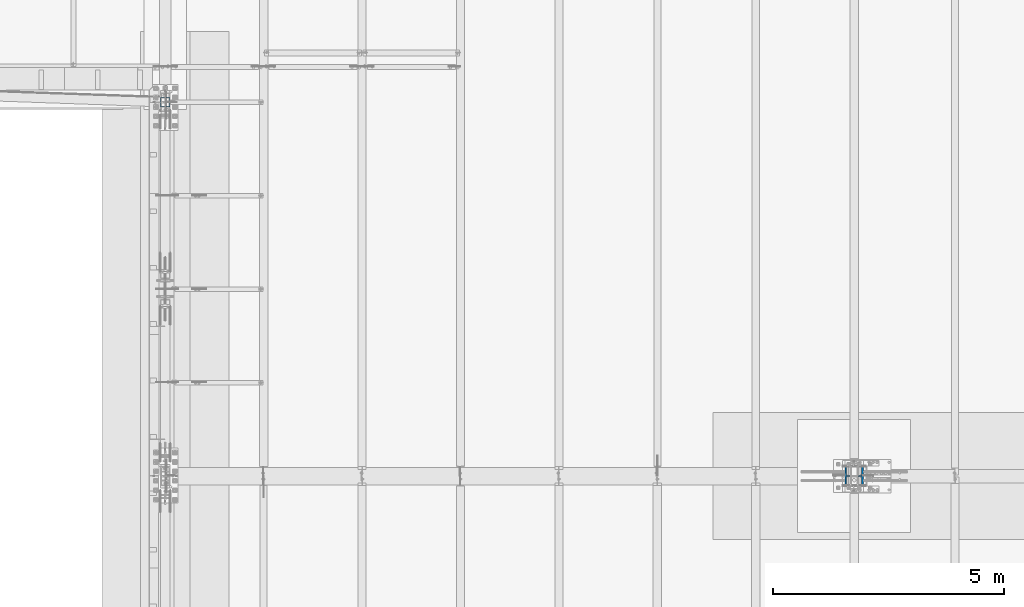
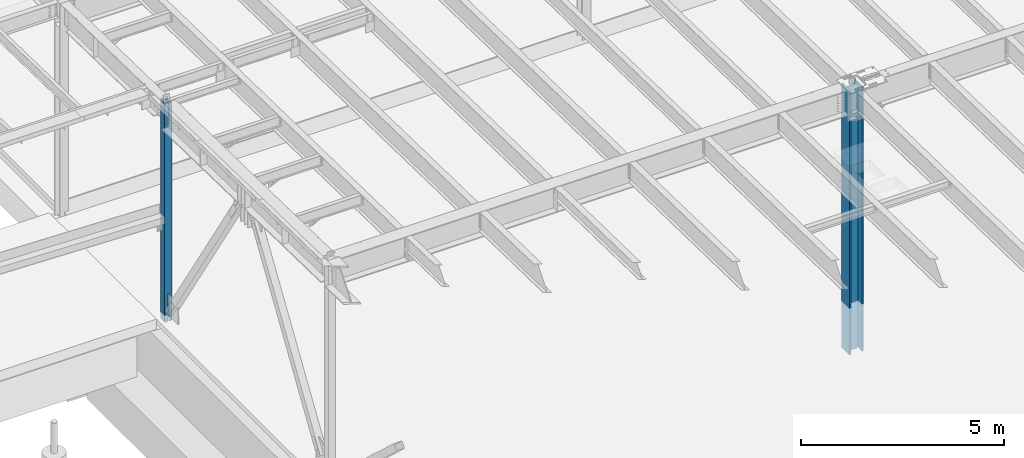
# One storey, part 887 of 1763: 2 columns, 2 elements without a shape of their own.
"""IFC2X3 building model written with IfcOpenShell, lengths in millimetres."""

import ifcopenshell
import ifcopenshell.guid

model = None  # the IFC model being written
_history = None  # IfcOwnerHistory: only IFC2X3 demands one
_inside = {}  # id of a spatial element -> (the spatial element, [elements in it])
_under = {}  # id of a project, library or spatial element -> (it, [spatial elements below it])
_declared = {}  # id of a project -> (the project, [libraries it declares])
_typed = {}  # id of a type object -> (the type object, [elements of that type])
_made_of = {}  # id of a material, layer set ... -> (it, [elements and type objects made of it])


def new_model(schema):
    """Start an empty IFC model of exactly this schema.

    Asked for "IFC4X3", IfcOpenShell would pick the latest addendum, in which some entities
    have other attributes; the version numbers below select the first issue.
    IFC2X3 requires an IfcOwnerHistory on every rooted entity: one is made here for all.
    """
    global model, _history
    if schema == "IFC4X3":
        model = ifcopenshell.file(schema_version=(4, 3, 0, 0))
    else:
        model = ifcopenshell.file(schema=schema)
    _inside.clear()
    _under.clear()
    _declared.clear()
    _typed.clear()
    _made_of.clear()
    _history = None
    if model.schema == "IFC2X3":
        org = make("IfcOrganization", Name="unknown")
        user = make(
            "IfcPersonAndOrganization",
            ThePerson=make("IfcPerson", FamilyName="unknown"),
            TheOrganization=org,
        )
        app = make(
            "IfcApplication",
            ApplicationDeveloper=org,
            Version="unknown",
            ApplicationFullName="unknown",
            ApplicationIdentifier="unknown",
        )
        _history = make(
            "IfcOwnerHistory",
            OwningUser=user,
            OwningApplication=app,
            ChangeAction="ADDED",
            CreationDate=0,
        )
    return model


def make(cls, **values):
    """One entity of the class cls with the attributes given. An attribute that is None is left unset."""
    return model.create_entity(
        cls, **{name: value for name, value in values.items() if value is not None}
    )


def rooted(cls, **values):
    """An entity with a GlobalId (a new one), such as an element, a storey or a relation."""
    return make(cls, GlobalId=ifcopenshell.guid.new(), OwnerHistory=_history, **values)


def si_unit(unit_type, name, prefix=None):
    """IfcSIUnit, for example si_unit("LENGTHUNIT", "METRE", prefix="MILLI")."""
    return make("IfcSIUnit", UnitType=unit_type, Prefix=prefix, Name=name)


def assignment(units):
    """IfcUnitAssignment: the units of a project."""
    return None if units is None else make("IfcUnitAssignment", Units=units)


def point(xyz):
    """IfcCartesianPoint."""
    return None if xyz is None else make("IfcCartesianPoint", Coordinates=xyz)


def direction(xyz):
    """IfcDirection."""
    return None if xyz is None else make("IfcDirection", DirectionRatios=xyz)


def frame(location, z_axis=None, x_axis=None):
    """IfcAxis2Placement3D, a coordinate frame: its origin and axes. An axis left out is left unset."""
    return make(
        "IfcAxis2Placement3D",
        Location=point(location),
        Axis=direction(z_axis),
        RefDirection=direction(x_axis),
    )


def origin_with_axes():
    """The frame at (0, 0, 0) with the z axis (0, 0, 1) and the x axis (1, 0, 0) written out."""
    return frame((0.0, 0.0, 0.0), z_axis=(0.0, 0.0, 1.0), x_axis=(1.0, 0.0, 0.0))


def place(relative_to, where):
    """IfcLocalPlacement: puts the frame where relative to a parent placement (None: the world)."""
    return make(
        "IfcLocalPlacement", PlacementRelTo=relative_to, RelativePlacement=where
    )


def context(
    kind, dimensions, precision=None, world=None, true_north=None, identifier=None
):
    """IfcGeometricRepresentationContext, for example the 3D "Model" context."""
    return make(
        "IfcGeometricRepresentationContext",
        ContextIdentifier=identifier,
        ContextType=kind,
        CoordinateSpaceDimension=dimensions,
        Precision=precision,
        WorldCoordinateSystem=world,
        TrueNorth=true_north,
    )


def subcontext(parent, identifier, kind, view, scale=None):
    """IfcGeometricRepresentationSubContext, for example "Body" below "Model"."""
    return make(
        "IfcGeometricRepresentationSubContext",
        ContextIdentifier=identifier,
        ContextType=kind,
        ParentContext=parent,
        TargetScale=scale,
        TargetView=view,
    )


def project(units=None, contexts=None):
    """IfcProject with its units and contexts."""
    return rooted(
        "IfcProject",
        Name="project",
        RepresentationContexts=contexts,
        UnitsInContext=assignment(units),
    )


def spatial(cls, under=None, at=None, **own):
    """A site, building, storey or space (cls), placed at a placement, below another one or the project."""
    s = rooted(cls, ObjectPlacement=at, **own)
    if under is not None:
        _under.setdefault(under.id(), (under, []))[1].append(s)
    return s


def faces_of(points, faces, orient=None, outer=None):
    """IfcFace entities. A face is a list of loops; a loop is a list of indices into points, from 0.

    orient and outer hold one flag for each loop. By default every Orientation is true, the
    first loop of a face is its IfcFaceOuterBound and the others are IfcFaceBound.
    """
    made = []
    for i, loops in enumerate(faces):
        bounds = []
        for j, loop in enumerate(loops):
            is_outer = j == 0 if outer is None else outer[i][j]
            bounds.append(
                make(
                    "IfcFaceOuterBound" if is_outer else "IfcFaceBound",
                    Bound=make("IfcPolyLoop", Polygon=[points[k] for k in loop]),
                    Orientation=True if orient is None else orient[i][j],
                )
            )
        made.append(make("IfcFace", Bounds=bounds))
    return made


def faceted_brep(points, faces, orient=None, outer=None, voids=None):
    """IfcFacetedBrep: a solid bounded by flat faces; with voids (closed shells), ...WithVoids."""
    shared = [point(p) for p in points]
    hull = make("IfcClosedShell", CfsFaces=faces_of(shared, faces, orient, outer))
    if voids is None:
        return make("IfcFacetedBrep", Outer=hull)
    return make(
        "IfcFacetedBrepWithVoids",
        Outer=hull,
        Voids=[
            make(cls, CfsFaces=faces_of(shared, fs, o, b)) for cls, fs, o, b in voids
        ],
    )


def shape(context_of_items, identifier, shape_type, items):
    """IfcShapeRepresentation: the items that make up one representation, for example the "Body"."""
    return make(
        "IfcShapeRepresentation",
        ContextOfItems=context_of_items,
        RepresentationIdentifier=identifier,
        RepresentationType=shape_type,
        Items=items,
    )


def material(Name=None, Category=None):
    """IfcMaterial."""
    return make("IfcMaterial", Name=Name, Category=Category)


def made_of(thing, what):
    """Note that an element or type object is made of a material, layer set ...; save() writes the relation."""
    if what is not None:
        _made_of.setdefault(what.id(), (what, []))[1].append(thing)
    return thing


def type_object(cls, material=None, **own):
    """A type object (cls), such as IfcWallType, which elements share."""
    return made_of(rooted(cls, **own), material)


def element(
    cls,
    number,
    at=None,
    inside=None,
    cuts=None,
    type_object=None,
    material=None,
    context=None,
    identifier="Body",
    shape_type=None,
    held_by="IfcProductDefinitionShape",
    body=None,
    shapes=None,
    **own,
):
    """One element of the class cls, such as IfcWall. Its Tag is "e" and its number.

    at: its placement. inside: the storey or other place that contains it. cuts: it is an
    opening in that element (IfcRelVoidsElement). A single representation is given by context,
    identifier, shape_type and body (its items); several are given by shapes. held_by: the class
    of the entity that holds the representations. save() writes the other relations.
    """
    e = rooted(cls, Tag="e%d" % number, ObjectPlacement=at, **own)
    if body is not None:
        shapes = [shape(context, identifier, shape_type, body)]
    if shapes is not None:
        e.Representation = make(held_by, Representations=shapes)
    if inside is not None:
        _inside.setdefault(inside.id(), (inside, []))[1].append(e)
    if cuts is not None:
        rooted(
            "IfcRelVoidsElement", RelatingBuildingElement=cuts, RelatedOpeningElement=e
        )
    if type_object is not None:
        _typed.setdefault(type_object.id(), (type_object, []))[1].append(e)
    return made_of(e, material)


def aggregate(whole, parts):
    """IfcRelAggregates: a whole, such as a stair, and the parts it consists of."""
    return rooted("IfcRelAggregates", RelatingObject=whole, RelatedObjects=parts)


def save(model, path):
    """Write the relations noted so far, then the file.

    IfcRelAggregates (storeys below a building ...), IfcRelContainedInSpatialStructure (elements
    in a storey), IfcRelDefinesByType, IfcRelAssociatesMaterial and IfcRelDeclares: one each for
    every whole, place, type object, material and project.
    """
    for whole, parts in _under.values():
        aggregate(whole, parts)
    for where, things in _inside.values():
        rooted(
            "IfcRelContainedInSpatialStructure",
            RelatedElements=things,
            RelatingStructure=where,
        )
    for kind, things in _typed.values():
        rooted("IfcRelDefinesByType", RelatedObjects=things, RelatingType=kind)
    for what, things in _made_of.values():
        rooted("IfcRelAssociatesMaterial", RelatedObjects=things, RelatingMaterial=what)
    for by, libraries in _declared.values():
        rooted("IfcRelDeclares", RelatingContext=by, RelatedDefinitions=libraries)
    model.write(path)


model = new_model("IFC2X3")

# Units and contexts
model_context = context("Model", 3, precision=1e-05, world=origin_with_axes())
body_context = subcontext(model_context, "Body", "Model", "MODEL_VIEW")
ifc_project = project(units=[si_unit("LENGTHUNIT", "METRE", prefix="MILLI"), si_unit("AREAUNIT", "SQUARE_METRE"), si_unit("VOLUMEUNIT", "CUBIC_METRE"), si_unit("MASSUNIT", "GRAM", prefix="KILO"), si_unit("TIMEUNIT", "SECOND"), si_unit("PLANEANGLEUNIT", "RADIAN"), si_unit("SOLIDANGLEUNIT", "STERADIAN"), si_unit("THERMODYNAMICTEMPERATUREUNIT", "DEGREE_CELSIUS"), si_unit("LUMINOUSINTENSITYUNIT", "LUMEN")], contexts=[model_context])

# Site, building, storey
site_placement = place(None, origin_with_axes())
site = spatial("IfcSite", under=ifc_project, at=site_placement, CompositionType="ELEMENT")
building_placement = place(site_placement, origin_with_axes())
building = spatial("IfcBuilding", under=site, at=building_placement, Name="Undefined", CompositionType="ELEMENT")
storey_placement = place(building_placement, origin_with_axes())
storey = spatial("IfcBuildingStorey", under=building, at=storey_placement, Name="Undefined", CompositionType="ELEMENT", Elevation=0.0)

# Assembly, column
assembly_1_placement = place(storey_placement, origin_with_axes())
assembly_1 = element("IfcElementAssembly", 1, at=assembly_1_placement, inside=storey, Name="COLUMN", AssemblyPlace="NOTDEFINED", PredefinedType="RIGID_FRAME")
ifc_material_1 = material()
column_type_1 = type_object("IfcColumnType", Name="HSS8X8X1/2", PredefinedType="NOTDEFINED")
column_1_placement = place(assembly_1_placement, frame((-87375.4372736983, 8534.40000000001, 5029.2), z_axis=(0.0, 1.0, 0.0), x_axis=(0.0, 0.0, 1.0)))
column_1 = element("IfcColumn", 2, at=column_1_placement, type_object=column_type_1, material=ifc_material_1, Name="COLUMN", ObjectType="HSS8X8X1/2", context=body_context, shape_type="Brep", body=[
    faceted_brep([(6684.93484998607, -88.8999999999942, -88.8999999999996), (6672.23484998607, -101.600000000006, -101.6), (6672.23484998607, 4.76249961853318, -101.6), (6684.93484998607, 4.76249961853318, -88.8999999999996), (6684.93484998607, -88.8999999999942, 88.8999999999996), (6672.23484998607, -101.600000000006, 101.6), (6684.93484998607, 88.8999999999942, 88.8999999999996), (6684.93484998607, 88.8999999999942, 10.3187499999967), (6672.23484998607, 101.600000000006, 10.3187499999967), (6672.23484998607, 101.600000000006, 101.6), (6684.93484998607, 26.9875000000029, -88.8999999999996), (6672.23484998607, 26.9875000000029, -101.6), (6672.23484998607, 101.600000000006, -101.6), (6684.93484998607, 88.8999999999942, -88.8999999999996), (6684.93484998607, 88.8999999999942, 0.793750381466452), (6672.23484998607, 101.600000000006, 0.793750381466452), (931.497778620195, -13.3207708403497, -88.8999999999996), (931.497778620195, -13.3207708403497, -101.6), (926.63769910215, -14.2875007629336, -101.6), (926.63769910215, -14.2875007629336, -88.8999999999996), (935.617955088349, -10.5677569398686, -88.8999999999996), (935.617955088349, -10.5677569398686, -101.6), (938.370968988827, -6.44758047170762, -88.8999999999996), (938.370968988827, -6.44758047170762, -101.6), (939.337698911415, -1.5875009536685, -88.8999999999996), (939.337698911415, -1.5875009536685, -101.6), (939.337698911415, 1.58750019074068, -88.8999999999996), (939.337698911415, 1.58750019074068, -101.6), (938.370968988827, 6.44757970877981, -88.8999999999996), (938.370968988827, 6.44757970877981, -101.6), (935.617955088349, 10.5677561769407, -88.8999999999996), (935.617955088349, 10.5677561769407, -101.6), (931.497778620195, 13.3207700774219, -88.8999999999996), (931.497778620195, 13.3207700774219, -101.6), (926.63769910215, 14.2875000000058, -88.8999999999996), (926.63769910215, 14.2875000000058, -101.6), (101.599999999998, 14.2875007629627, -88.9), (101.599999999998, 14.2875007629627, -101.6), (6511.84203632012, 88.8999999999942, 10.3187499999967), (6511.84203632012, 101.600000000006, 10.3187499999967), (6510.37034294335, 88.8999999999942, 10.0856566681869), (6510.37034294335, 101.600000000006, 10.0856566681869), (6509.04270916819, 88.8999999999942, 9.40919347213458), (6509.04270916819, 101.600000000006, 9.40919347213458), (6507.98909303872, 88.8999999999942, 8.35557734266331), (6507.98909303872, 101.600000000006, 8.35557734266331), (6507.31262984266, 88.8999999999942, 7.02794356750201), (6507.31262984266, 101.600000000006, 7.02794356750201), (6507.07953651085, 88.8999999999942, 5.55625019073159), (6507.07953651085, 101.600000000006, 5.55625019073159), (6507.31262984266, 88.8999999999942, 4.08455681396117), (6507.31262984266, 101.600000000006, 4.08455681396117), (6507.98909303872, 88.8999999999942, 2.75692303879987), (6507.98909303872, 101.600000000006, 2.75692303879987), (6509.04270916819, 88.8999999999942, 1.7033069093286), (6509.04270916819, 101.600000000006, 1.7033069093286), (6510.37034294335, 88.8999999999942, 1.02684371327632), (6510.37034294335, 101.600000000006, 1.02684371327632), (6511.84203632012, 88.8999999999942, 0.793750381466452), (6511.84203632012, 101.600000000006, 0.793750381466452), (6028.5118970698, 4.76249961853318, 88.8999999999996), (6028.5118970698, 4.76249961853318, 101.6), (6672.23484998607, 4.76249961853318, 101.6), (6684.93484998607, 4.76249961853318, 88.8999999999996), (6024.25932735465, 5.60838832802256, 88.8999999999996), (6024.25932735465, 5.60838832802256, 101.6), (6020.65417282899, 8.01727556846163, 88.8999999999996), (6020.65417282899, 8.01727556846163, 101.6), (6018.24528558855, 11.6224300941249, 88.8999999999996), (6018.24528558855, 11.6224300941249, 101.6), (6017.39939687906, 15.874999809268, 88.8999999999996), (6017.39939687906, 15.874999809268, 101.6), (6018.24528558855, 20.1275695244112, 88.8999999999996), (6018.24528558855, 20.1275695244112, 101.6), (6020.65417282899, 23.7327240500745, 88.8999999999996), (6020.65417282899, 23.7327240500745, 101.6), (6024.25932735465, 26.1416112905135, 88.8999999999996), (6024.25932735465, 26.1416112905135, 101.6), (6028.5118970698, 26.9875000000029, 88.8999999999996), (6028.5118970698, 26.9875000000029, 101.6), (6684.93484998607, 26.9875000000029, 88.8999999999996), (6672.23484998607, 26.9875000000029, 101.6), (101.599999999999, -101.599999999999, 101.6), (101.599999999999, -101.599999999999, -101.6), (101.599999999999, 101.599999999999, 101.6), (101.600000000009, 14.2875007629336, 101.6), (926.63769910215, 14.2875000000058, 101.6), (931.497778620195, 13.3207700774219, 101.6), (935.617955088349, 10.5677561769407, 101.6), (938.370968988827, 6.44757970877981, 101.6), (939.337698911415, 1.58750019074068, 101.6), (939.337698911415, -1.5875009536685, 101.6), (938.370968988827, -6.44758047170762, 101.6), (935.617955088349, -10.5677569398686, 101.6), (931.497778620195, -13.3207708403497, 101.6), (926.63769910215, -14.2875007629336, 101.6), (101.600000000009, -14.2875000000058, 101.6), (101.599999999999, 101.599999999999, -101.6), (6028.51188020661, 26.9875000000029, -88.8999999999996), (6028.51188020661, 26.9875000000029, -101.6), (6024.25931049146, 26.1416112905135, -88.8999999999996), (6024.25931049146, 26.1416112905135, -101.6), (6020.6541559658, 23.7327240500745, -88.8999999999996), (6020.6541559658, 23.7327240500745, -101.6), (6018.24526872536, 20.1275695244112, -88.8999999999996), (6018.24526872536, 20.1275695244112, -101.6), (6017.39938001587, 15.874999809268, -88.8999999999996), (6017.39938001587, 15.874999809268, -101.6), (6018.24526872536, 11.6224300941249, -88.8999999999996), (6018.24526872536, 11.6224300941249, -101.6), (6020.6541559658, 8.01727556846163, -88.8999999999996), (6020.6541559658, 8.01727556846163, -101.6), (6024.25931049146, 5.60838832802256, -88.8999999999996), (6024.25931049146, 5.60838832802256, -101.6), (6028.51188020661, 4.76249961853318, -88.8999999999996), (6028.51188020661, 4.76249961853318, -101.6), (101.599999999998, -14.2874999999622, -101.6), (101.599999999998, -14.2874999999622, -88.9), (101.599999999999, 88.9000000000015, -88.8999999999996), (101.599999999999, -88.9000000000015, -88.8999999999996), (101.599999999999, 88.9000000000015, 88.8999999999996), (101.600000000009, 14.2875007629336, 88.8999999999996), (926.63769910215, 14.2875000000058, 88.8999999999996), (931.497778620195, 13.3207700774219, 88.8999999999996), (935.617955088349, 10.5677561769407, 88.8999999999996), (938.370968988827, 6.44757970877981, 88.8999999999996), (939.337698911415, 1.58750019074068, 88.8999999999996), (939.337698911415, -1.5875009536685, 88.8999999999996), (938.370968988827, -6.44758047170762, 88.8999999999996), (935.617955088349, -10.5677569398686, 88.8999999999996), (931.497778620195, -13.3207708403497, 88.8999999999996), (926.63769910215, -14.2875007629336, 88.8999999999996), (101.600000000009, -14.2875000000058, 88.8999999999996), (101.599999999999, -88.9000000000015, 88.8999999999996)], [[[0, 1, 2, 3]], [[4, 5, 1, 0]], [[6, 7, 8, 9]], [[10, 11, 12, 13]], [[14, 13, 12, 15]], [[16, 17, 18, 19]], [[20, 21, 17, 16]], [[22, 23, 21, 20]], [[24, 25, 23, 22]], [[26, 27, 25, 24]], [[28, 29, 27, 26]], [[30, 31, 29, 28]], [[32, 33, 31, 30]], [[34, 35, 33, 32]], [[36, 37, 35, 34]], [[38, 39, 8, 7]], [[40, 41, 39, 38]], [[42, 43, 41, 40]], [[44, 45, 43, 42]], [[46, 47, 45, 44]], [[48, 49, 47, 46]], [[50, 51, 49, 48]], [[52, 53, 51, 50]], [[54, 55, 53, 52]], [[56, 57, 55, 54]], [[58, 59, 57, 56]], [[59, 58, 14, 15]], [[60, 61, 62, 63]], [[61, 60, 64, 65]], [[65, 64, 66, 67]], [[67, 66, 68, 69]], [[69, 68, 70, 71]], [[71, 70, 72, 73]], [[73, 72, 74, 75]], [[75, 74, 76, 77]], [[77, 76, 78, 79]], [[79, 78, 80, 81]], [[82, 83, 1, 5]], [[61, 65, 67, 69, 71, 73, 75, 77, 79, 81, 9, 84, 85, 86, 87, 88, 89, 90, 91, 92, 93, 94, 95, 96, 82, 5, 62]], [[39, 41, 43, 45, 47, 49, 51, 53, 55, 57, 59, 15, 12, 97, 84, 9, 8]], [[98, 99, 11, 10]], [[100, 101, 99, 98]], [[102, 103, 101, 100]], [[104, 105, 103, 102]], [[106, 107, 105, 104]], [[108, 109, 107, 106]], [[110, 111, 109, 108]], [[112, 113, 111, 110]], [[114, 115, 113, 112]], [[115, 114, 3, 2]], [[83, 116, 18, 17, 21, 23, 25, 27, 29, 31, 33, 35, 37, 97, 12, 11, 99, 101, 103, 105, 107, 109, 111, 113, 115, 2, 1]], [[19, 18, 116, 117]], [[114, 112, 110, 108, 106, 104, 102, 100, 98, 10, 13, 118, 36, 34, 32, 30, 28, 26, 24, 22, 20, 16, 19, 117, 119, 0, 3]], [[84, 97, 37, 36, 118, 120, 121, 85]], [[85, 121, 122, 86]], [[86, 122, 123, 87]], [[87, 123, 124, 88]], [[88, 124, 125, 89]], [[89, 125, 126, 90]], [[90, 126, 127, 91]], [[91, 127, 128, 92]], [[92, 128, 129, 93]], [[93, 129, 130, 94]], [[94, 130, 131, 95]], [[95, 131, 132, 96]], [[133, 119, 117, 116, 83, 82, 96, 132]], [[119, 133, 4, 0]], [[63, 62, 5, 4]], [[133, 132, 131, 130, 129, 128, 127, 126, 125, 124, 123, 122, 121, 120, 6, 80, 78, 76, 74, 72, 70, 68, 66, 64, 60, 63, 4]], [[81, 80, 6, 9]], [[120, 118, 13, 14, 58, 56, 54, 52, 50, 48, 46, 44, 42, 40, 38, 7, 6]]]),
])
aggregate(assembly_1, [column_1])

assembly_2_placement = place(storey_placement, origin_with_axes())
assembly_2 = element("IfcElementAssembly", 3, at=assembly_2_placement, inside=storey, Name="COLUMN", AssemblyPlace="NOTDEFINED", PredefinedType="RIGID_FRAME")
ifc_material_2 = material(Name="STEEL/A992")
column_type_2 = type_object("IfcColumnType", Name="W14X211", PredefinedType="NOTDEFINED")
column_2_placement = place(assembly_2_placement, frame((-72491.0372736972, 457.200000000843, 3810.0), z_axis=(-1.0, 0.0, 0.0), x_axis=(0.0, 0.0, 1.0)))
column_2 = element("IfcColumn", 4, at=column_2_placement, type_object=column_type_2, material=ifc_material_2, Name="COLUMN", ObjectType="W14X211", context=body_context, shape_type="Brep", body=[
    faceted_brep([(124.513583392817, -200.025, 200.025000000001), (124.513583392817, 200.025, 200.025000000001), (101.600000000001, 200.025, 160.337500000001), (101.600000000001, 12.7, 160.337500000001), (101.600000000001, -12.7, 160.337500000001), (101.600000000001, -200.025, 160.337500000001), (8069.82117149519, 12.7, -160.337500000001), (8069.82117149519, 200.025, -160.337500000001), (101.600000000001, 200.025, -160.337500000001), (101.600000000001, 12.7, -160.337500000001), (8069.82117149519, -200.025, 160.337500000001), (8069.82117149519, -200.025, 200.025000000001), (8069.82117149519, -12.7, 160.337500000001), (8069.82117149519, 12.7, 160.337500000001), (8069.82117149519, 200.025, 160.337500000001), (8069.82117149519, 200.025, 200.025000000001), (8069.82117149519, -12.7, -160.337500000001), (8069.82117149519, -200.025, -160.337500000001), (8069.82117149519, -200.025, -200.025000000001), (8069.82117149519, 200.025, -200.025000000001), (101.600000000001, -12.7, -160.337500000001), (101.600000000001, -200.025, -160.337500000001), (124.513591400617, -200.025, -200.025000000001), (124.513591400617, 200.025, -200.025000000001), (101.600000000001, -12.7, -159.940498626711), (101.600000000001, 12.7, -159.940498626711), (152.400000000001, -12.7, -159.940498626711), (152.400000000001, 12.7000000000032, -159.940498626711), (152.400000000001, -12.7, -136.525499618532), (152.400000000001, 12.7000000000032, -136.525499618532), (151.674952576209, -12.7, -132.88044007124), (151.674952576209, 12.7000000000032, -132.88044007124), (149.610192202533, -12.7, -129.79030779747), (149.610192202533, 12.7000000000032, -129.79030779747), (146.520059928766, -12.7, -127.725547423797), (146.520059928766, 12.7000000000032, -127.725547423797), (142.875000381471, -12.7, -127.000500000002), (142.875000381471, 12.7000000000032, -127.000500000002), (101.600000000001, -12.7, -127.000000000015), (126.999999618533, 12.7000000000071, -127.000000000015), (101.600000000001, -12.7, 126.999999999985), (126.999999618533, 12.7000000000071, 126.999999999985), (142.87500190735, -12.7, 127.000500000002), (142.87500190735, 12.7000000000032, 127.000500000002), (146.520061454645, -12.7, 127.725547423797), (146.520061454645, 12.7000000000032, 127.725547423797), (149.610193728412, -12.7, 129.79030779747), (149.610193728412, 12.7000000000032, 129.79030779747), (151.674954102088, -12.7, 132.88044007124), (151.674954102088, 12.7000000000032, 132.88044007124), (152.40000152588, -12.7, 136.525499618532), (152.40000152588, 12.7000000000032, 136.525499618532), (152.40000152588, -12.7, 159.940498626711), (152.40000152588, 12.7000000000032, 159.940498626711), (101.600000000001, -12.7, 159.940498626711), (101.600000000001, 12.7, 159.940498626711)], [[[0, 1, 2, 3, 4, 5]], [[6, 7, 8, 9]], [[10, 11, 0, 5]], [[12, 10, 5, 4]], [[6, 13, 14, 15, 11, 10, 12, 16, 17, 18, 19, 7]], [[17, 16, 20, 21]], [[18, 17, 21, 22]], [[19, 18, 22, 23]], [[7, 19, 23, 8]], [[22, 21, 20, 9, 8, 23]], [[9, 20, 24, 25]], [[26, 27, 25, 24]], [[28, 29, 27, 26]], [[30, 31, 29, 28]], [[32, 33, 31, 30]], [[34, 35, 33, 32]], [[36, 37, 35, 34]], [[38, 39, 37, 36]], [[39, 38, 40, 41]], [[42, 43, 41, 40]], [[44, 45, 43, 42]], [[46, 47, 45, 44]], [[48, 49, 47, 46]], [[50, 51, 49, 48]], [[52, 53, 51, 50]], [[48, 46, 44, 42, 40, 38, 36, 34, 32, 30, 28, 26, 24, 20, 16, 12, 4, 54, 52, 50]], [[55, 54, 4, 3]], [[53, 52, 54, 55]], [[3, 13, 6, 9, 25, 27, 29, 31, 33, 35, 37, 39, 41, 43, 45, 47, 49, 51, 53, 55]], [[14, 13, 3, 2]], [[15, 14, 2, 1]], [[11, 15, 1, 0]]]),
])
aggregate(assembly_2, [column_2])

save(model, "model.ifc")
